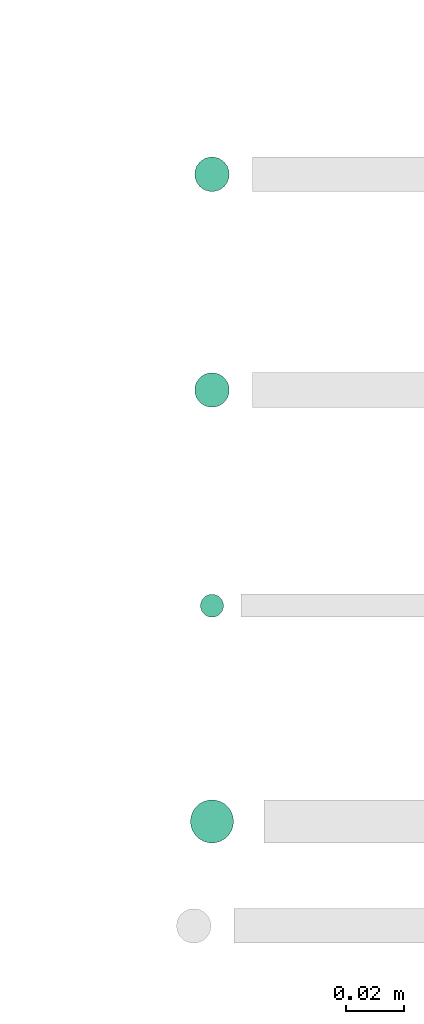
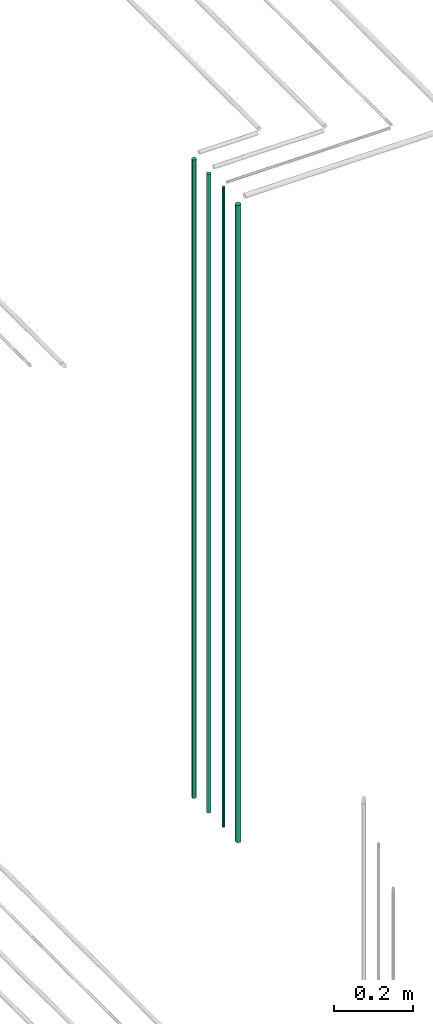
# One storey, part 68 of 331: 4 flow segments.
"""IFC2X3 building model written with IfcOpenShell, lengths in millimetres."""

from ifc_helpers import new_model, entity, si_unit, converted_unit, derived_unit, direction, frame, frame_2d, origin, origin_2d_with_axis, place, context, subcontext, project, spatial, circle, extrude, type_object, element, save


model = new_model("IFC2X3")

# Units and contexts
model_context = context("Model", 3, precision=0.01, world=origin(), true_north=direction((6.12303176911189e-17, 1.0)))
body_context = subcontext(model_context, "Body", "Model", "MODEL_VIEW")
ifc_project = project(units=[si_unit("LENGTHUNIT", "METRE", prefix="MILLI"), si_unit("AREAUNIT", "SQUARE_METRE"), si_unit("VOLUMEUNIT", "CUBIC_METRE"), converted_unit("PLANEANGLEUNIT", "DEGREE", entity("IfcRatioMeasure", 0.0174532925199433), si_unit("PLANEANGLEUNIT", "RADIAN"), dimensions=[0, 0, 0, 0, 0, 0, 0]), si_unit("MASSUNIT", "GRAM", prefix="KILO"), derived_unit("MASSDENSITYUNIT", [(si_unit("MASSUNIT", "GRAM", prefix="KILO"), 1), (si_unit("LENGTHUNIT", "METRE"), -3)]), derived_unit("MOMENTOFINERTIAUNIT", [(si_unit("LENGTHUNIT", "METRE"), 4)]), si_unit("TIMEUNIT", "SECOND"), si_unit("FREQUENCYUNIT", "HERTZ"), si_unit("THERMODYNAMICTEMPERATUREUNIT", "DEGREE_CELSIUS"), derived_unit("THERMALTRANSMITTANCEUNIT", [(si_unit("MASSUNIT", "GRAM", prefix="KILO"), 1), (si_unit("THERMODYNAMICTEMPERATUREUNIT", "KELVIN"), -1), (si_unit("TIMEUNIT", "SECOND"), -3)]), derived_unit("VOLUMETRICFLOWRATEUNIT", [(si_unit("LENGTHUNIT", "METRE"), 3), (si_unit("TIMEUNIT", "SECOND"), -1)]), derived_unit("MASSFLOWRATEUNIT", [(si_unit("MASSUNIT", "GRAM", prefix="KILO"), 1), (si_unit("TIMEUNIT", "SECOND"), -1)]), derived_unit("ROTATIONALFREQUENCYUNIT", [(si_unit("TIMEUNIT", "SECOND"), -1)]), si_unit("ELECTRICCURRENTUNIT", "AMPERE"), si_unit("ELECTRICVOLTAGEUNIT", "VOLT"), si_unit("POWERUNIT", "WATT"), si_unit("FORCEUNIT", "NEWTON", prefix="KILO"), si_unit("ILLUMINANCEUNIT", "LUX"), si_unit("LUMINOUSFLUXUNIT", "LUMEN"), si_unit("LUMINOUSINTENSITYUNIT", "CANDELA"), derived_unit("USERDEFINED", [(si_unit("MASSUNIT", "GRAM", prefix="KILO"), -1), (si_unit("LENGTHUNIT", "METRE"), -2), (si_unit("TIMEUNIT", "SECOND"), 3), (si_unit("LUMINOUSFLUXUNIT", "LUMEN"), 1)]), derived_unit("LINEARVELOCITYUNIT", [(si_unit("LENGTHUNIT", "METRE"), 1), (si_unit("TIMEUNIT", "SECOND"), -1)]), si_unit("PRESSUREUNIT", "PASCAL"), derived_unit("USERDEFINED", [(si_unit("LENGTHUNIT", "METRE"), -2), (si_unit("MASSUNIT", "GRAM", prefix="KILO"), 1), (si_unit("TIMEUNIT", "SECOND"), -2)]), derived_unit("LINEARFORCEUNIT", [(si_unit("MASSUNIT", "GRAM", prefix="KILO"), 1), (si_unit("LENGTHUNIT", "METRE"), 1), (si_unit("TIMEUNIT", "SECOND"), -2), (si_unit("LENGTHUNIT", "METRE"), -1)]), derived_unit("PLANARFORCEUNIT", [(si_unit("MASSUNIT", "GRAM", prefix="KILO"), 1), (si_unit("LENGTHUNIT", "METRE"), 1), (si_unit("TIMEUNIT", "SECOND"), -2), (si_unit("LENGTHUNIT", "METRE"), -2)])], contexts=[model_context])

# Site, building, storey
site_placement = place(None, frame((0.0, -0.00077364408347762, 0.0)))
site = spatial("IfcSite", under=ifc_project, at=site_placement, CompositionType="ELEMENT")
building_placement = place(site_placement, origin())
building = spatial("IfcBuilding", under=site, at=building_placement, CompositionType="ELEMENT")
storey_placement = place(building_placement, origin())
storey = spatial("IfcBuildingStorey", under=building, at=storey_placement, CompositionType="ELEMENT", Elevation=0.0)

# Flow segments
pipe_segment_type = type_object("IfcPipeSegmentType", PredefinedType="NOTDEFINED")
flow_segment_1_placement = place(storey_placement, frame((62767.0166110417, 2695.84830470758, 17050.0)))
element("IfcFlowSegment", 1, at=flow_segment_1_placement, inside=storey, type_object=pipe_segment_type, context=body_context, shape_type="SweptSolid", body=[
    extrude(circle(Radius=7.5, at=frame_2d((0.0, 5.41433564649196e-13), x_axis=(1.0, 0.0))), frame((9.09527223591419, 9.09527223591528, 0.0)), (0.0, 0.0, 1.0), 1982.0),
])
flow_segment_2_placement = place(storey_placement, frame((62770.5166110417, 2774.34830470759, 17050.0)))
element("IfcFlowSegment", 2, at=flow_segment_2_placement, inside=storey, type_object=pipe_segment_type, context=body_context, shape_type="SweptSolid", body=[
    extrude(circle(Radius=4.0, at=origin_2d_with_axis()), frame((5.59527223591499, 5.59527223591607, 0.0)), (0.0, 0.0, 1.0), 1990.0),
])
for number, where in (
    (3, (62768.5166110417, 2847.34830470759, 17050.0)),
    (4, (62768.5166110417, 2922.34830470759, 17050.0)),
):
    element("IfcFlowSegment", number, at=place(storey_placement, frame(where)), inside=storey, type_object=pipe_segment_type, context=body_context, shape_type="SweptSolid", body=[
        extrude(circle(Radius=6.0, at=origin_2d_with_axis()), frame((7.59527223591454, 7.59527223591616, 0.0)), (0.0, 0.0, 1.0), 1986.0),
    ])

save(model, "model.ifc")
